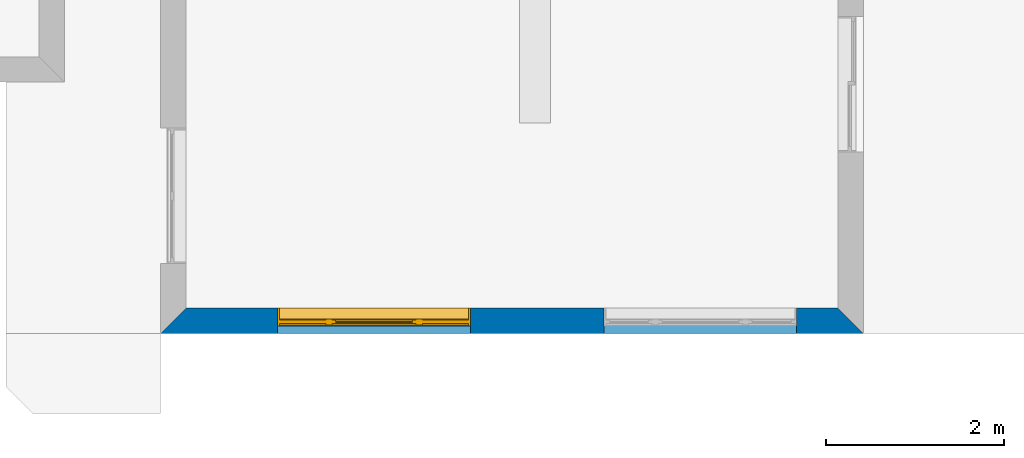
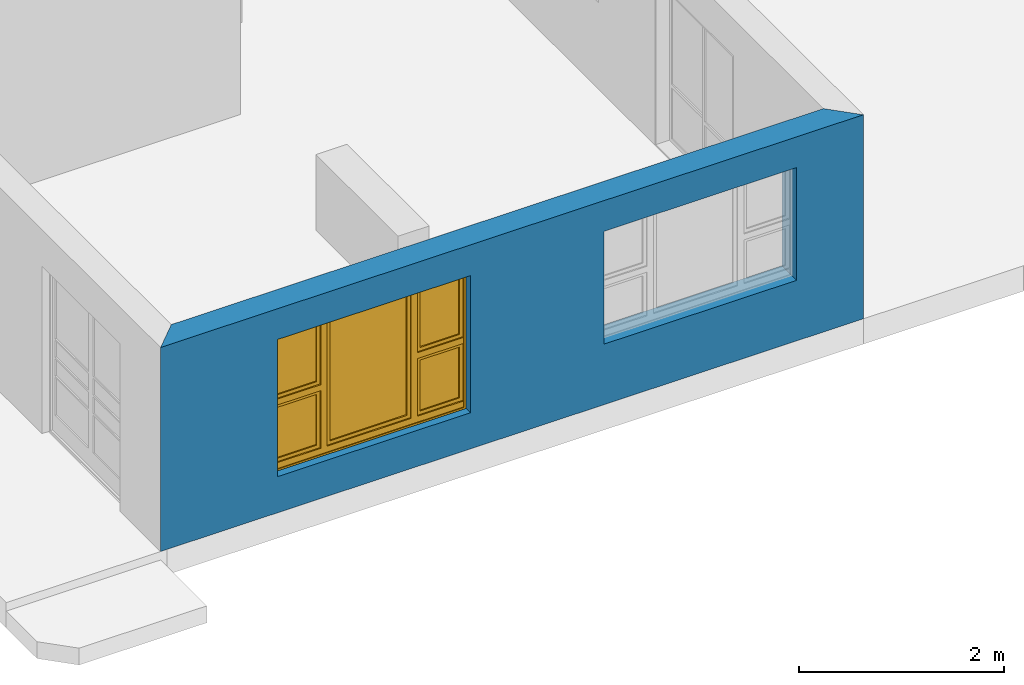
# One storey, part 4 of 15: 1 wall, 1 window, 2 openings.
"""IFC4 building model written with IfcOpenShell, lengths in millimetres."""

from ifc_helpers import new_model, entity, si_unit, converted_unit, frame, origin_with_axes, origin_2d_with_axis, place, context, subcontext, project, spatial, line, indexed_curve, outline, extrude, clip, halfspace, polygons, source, transform, mapped, material, layer, layer_set, layer_usage, type_object, type_shapes, element, fill, save


model = new_model("IFC4")

# Units and contexts
model_context = context("Model", 3, precision=1e-05, world=origin_with_axes())
plan_context = context("Plan", 2, precision=1e-05, world=origin_2d_with_axis())
body_context = subcontext(model_context, "Body", "Model", "MODEL_VIEW")
ifc_project = project(units=[si_unit("VOLUMEUNIT", "CUBIC_METRE"), si_unit("LENGTHUNIT", "METRE", prefix="MILLI"), converted_unit("PLANEANGLEUNIT", "degree", entity("IfcReal", 0.0174532925199433), si_unit("PLANEANGLEUNIT", "RADIAN"), dimensions=[0, 0, 0, 0, 0, 0, 0]), si_unit("AREAUNIT", "SQUARE_METRE")], contexts=[model_context, plan_context])

# Site, building, storey
site_placement = place(None, origin_with_axes())
site = spatial("IfcSite", under=ifc_project, at=site_placement)
building_placement = place(site_placement, origin_with_axes())
building = spatial("IfcBuilding", under=site, at=building_placement, Name="Building")
storey_placement = place(building_placement, origin_with_axes())
storey = spatial("IfcBuildingStorey", under=building, at=storey_placement, Name="EXISTING")

# Wall, openings, window
ifc_material = material()
ifc_layer = layer(ifc_material, 285.0, Name="brick")
ifc_layer_set = layer_set([ifc_layer])
ifc_layer_usage = layer_usage(ifc_layer_set, "AXIS2", "POSITIVE", 0.0)
wall_type = type_object("IfcWallType", Name="285mm Wall", PredefinedType="STANDARD", material=ifc_layer_set)
wall_placement = place(storey_placement, frame((5594.11907196045, -4518.33248138428, 0.0), z_axis=(0.0, 0.0, 1.0), x_axis=(0.999999999999993, 1.19209282445353e-07, 0.0)))
wall = element("IfcWall", 1, at=wall_placement, inside=storey, type_object=wall_type, material=ifc_layer_usage, Name="Wall", context=body_context, shape_type="Clipping", body=[
    clip(clip(extrude(outline(indexed_curve([(0.0, 0.0), (0.0, 285.0), (7900.00095608862, 285.0), (7900.00095608862, 0.0), (0.0, 0.0)], self_intersect=False)), origin_with_axes(), (0.0, 0.0, 1.0), 2425.00019073486), halfspace(frame((7900.00104904175, 0.0, 0.0), z_axis=(0.707107067108154, 0.707106471061707, 0.0), x_axis=(0.707106483163256, -0.707107079209714, 0.0)), False)), halfspace(frame((0.0, 0.0, 0.0), z_axis=(-0.707106471061707, 0.707107067108154, 0.0), x_axis=(0.707107079209714, 0.707106483163256, 0.0)), False)),
])
shared_shape_1 = source(origin_with_axes(), body_context, "Body", "SweptSolid", [
    extrude(outline(indexed_curve([(0.0, 0.0), (2165.00024414062, 0.0), (2165.00024414062, 1629.99987792969), (0.0, 1629.99987792969)], segments=[line(1, 2, 3, 4, 1)])), frame((-1.04308121251506e-07, -600.0, 0.0), z_axis=(0.0, -1.0, 0.0), x_axis=(1.0, 0.0, 0.0)), (0.0, 0.0, -1.0), 1200.0),
])
opening_1_placement = place(wall_placement, frame((3482.00082778931, 136.111021041866, 430.000007152557), z_axis=(0.0, 0.0, 1.0), x_axis=(-0.999999999999989, 1.50995802528085e-07, 0.0)))
opening_1 = element("IfcOpeningElement", 2, at=opening_1_placement, cuts=wall, Name="Opening", PredefinedType="OPENING", context=body_context, shape_type="MappedRepresentation", body=[
    mapped(shared_shape_1, transform((0.0, 0.0, 0.0), x_axis=(1.0, 0.0, 0.0), y_axis=(0.0, 1.0, 0.0), z_axis=(0.0, 0.0, 1.0), scale=1.0)),
])
shared_shape_2 = source(origin_with_axes(), body_context, "Body", "SweptSolid", [
    extrude(outline(indexed_curve([(0.0, 0.0), (2165.00048828125, 0.0), (2165.00048828125, 1340.00048828125), (0.0, 1340.00048828125)], segments=[line(1, 2, 3, 4, 1)])), frame((-5.96046390910487e-07, -600.0, 0.0), z_axis=(0.0, -1.0, 0.0), x_axis=(1.0, 0.0, 0.0)), (0.0, 0.0, -1.0), 1200.0),
])
opening_2_placement = place(wall_placement, frame((7150.00581741333, 136.111021041866, 719.999313354492), z_axis=(0.0, 0.0, 1.0), x_axis=(-0.999999999999989, 1.50995802528085e-07, 0.0)))
element("IfcOpeningElement", 3, at=opening_2_placement, cuts=wall, PredefinedType="OPENING", context=body_context, shape_type="MappedRepresentation", body=[
    mapped(shared_shape_2, transform((0.0, 0.0, 0.0), x_axis=(1.0, 0.0, 0.0), y_axis=(0.0, 1.0, 0.0), z_axis=(0.0, 0.0, 1.0), scale=1.0)),
])
window_type = type_object("IfcWindowType", Name="Ex.2165x1630", PartitioningType="NOTDEFINED", PredefinedType="WINDOW")
shared_shape_3 = source(origin_with_axes(), body_context, "Body", "Tessellation", [
    polygons([(2165.00048828125, -148.88883972168, 0.0), (2165.00048828125, -148.88883972168, 19.9999198913574), (0.000134110436192714, -148.888961791992, 0.0), (0.000134110436192714, -148.888961791992, 19.9999198913574), (2165.00048828125, 51.1111831665039, 0.0), (2165.00048828125, 51.1111831665039, 19.9999198913574), (0.000134110436192714, 51.1110649108887, 0.0), (0.000134110436192714, 51.1110649108887, 19.9999198913574), (2165.00048828125, -148.88883972168, 1609.99975585938), (2165.00048828125, -148.88883972168, 1630.0), (0.000134110436192714, -148.888961791992, 1609.99975585938), (0.000134110436192714, -148.888961791992, 1630.0), (2165.00048828125, 51.1111831665039, 1609.99975585938), (2165.00048828125, 51.1111831665039, 1630.0), (0.000134110436192714, 51.1110649108887, 1609.99975585938), (0.000134110436192714, 51.1110649108887, 1630.0), (0.000134110436192714, -148.88883972168, 19.9999198913574), (20.0003528594971, -148.88883972168, 19.9999198913574), (0.000134110436192714, -148.888961791992, 1609.99975585938), (20.000114440918, -148.888961791992, 1609.99975585938), (0.000134110436192714, 51.1111831665039, 19.9999198913574), (20.000114440918, 51.1111831665039, 19.9999198913574), (-0.000104308121080976, 51.1110649108887, 1609.99975585938), (20.000114440918, 51.1110649108887, 1609.99975585938), (2145.00048828125, -148.88883972168, 19.9999198913574), (2165.00048828125, -148.88883972168, 19.9999198913574), (2145.0, -148.888961791992, 1609.99975585938), (2165.0, -148.888961791992, 1609.99975585938), (2145.00048828125, 51.1111831665039, 19.9999198913574), (2165.00048828125, 51.1111831665039, 19.9999198913574), (2145.0, 51.1110649108887, 1609.99975585938), (2165.0, 51.1110649108887, 1609.99975585938), (1554.99987792969, -28.8888530731201, 19.9999198913574), (1625.0, -28.8888530731201, 19.9999198913574), (1554.99938964844, -28.8888530731201, 1609.99975585938), (1624.99951171875, -28.8888530731201, 1609.99975585938), (1554.99987792969, 41.1110763549805, 19.9999198913574), (1625.0, 41.1110763549805, 19.9999198913574), (1554.99938964844, 41.1110763549805, 1609.99975585938), (1624.99951171875, 41.1110763549805, 1609.99975585938), (540.000061035156, -28.8888530731201, 19.9999198913574), (610.000244140625, -28.8888530731201, 19.9999198913574), (539.999816894531, -28.8888530731201, 1609.99975585938), (610.0, -28.8888530731201, 1609.99975585938), (540.000061035156, 41.1110763549805, 19.9999198913574), (610.000244140625, 41.1110763549805, 19.9999198913574), (539.999816894531, 41.1110763549805, 1609.99975585938), (610.0, 41.1110763549805, 1609.99975585938), (20.000114440918, -28.888973236084, 844.999328613281), (20.000114440918, -28.888973236084, 775.000122070312), (540.000061035156, -28.8888530731201, 845.000061035156), (540.000061035156, -28.8888530731201, 775.000793457031), (20.000114440918, 41.1110763549805, 844.999328613281), (20.000114440918, 41.1110763549805, 775.000122070312), (540.000061035156, 41.1110763549805, 845.000061035156), (540.000061035156, 41.1111946105957, 775.000793457031), (1625.0, -28.888973236084, 844.999328613281), (1625.0, -28.888973236084, 775.000122070312), (2145.0, -28.8888530731201, 845.000061035156), (2145.0, -28.8888530731201, 775.000793457031), (1625.0, 41.1110763549805, 844.999328613281), (1625.0, 41.1110763549805, 775.000122070312), (2145.0, 41.1110763549805, 845.000061035156), (2145.0, 41.1111946105957, 775.000793457031), (1625.0, -13.8889875411987, 1609.99951171875), (1625.0, -13.8889875411987, 1569.99987792969), (2145.0, -13.8888683319092, 1609.99975585938), (2145.0, -13.8888683319092, 1570.00061035156), (1625.0, 26.1110916137695, 1609.99951171875), (1625.0, 26.1110916137695, 1569.99987792969), (2145.0, 26.1110916137695, 1610.00024414062), (2145.0, 26.1110916137695, 1570.00061035156), (1625.0, -13.8889875411987, 884.9990234375), (1625.0, -13.8889875411987, 844.999328613281), (2145.0, -13.8888683319092, 884.99951171875), (2145.0, -13.8888683319092, 844.999938964844), (1625.0, 26.1110916137695, 884.9990234375), (1625.0, 26.1110916137695, 844.999328613281), (2145.0, 26.1110916137695, 884.99951171875), (2145.0, 26.1110916137695, 844.999938964844), (1665.0, -13.8888683319092, 1570.00012207031), (1625.0, -13.8888683319092, 1570.00012207031), (1664.99975585938, -13.8888683319092, 884.9990234375), (1625.0, -13.8888683319092, 884.9990234375), (1665.0, 26.1110916137695, 1570.00012207031), (1625.0, 26.1110916137695, 1570.00012207031), (1664.99975585938, 26.1110916137695, 884.9990234375), (1625.0, 26.1110916137695, 884.9990234375), (2144.99951171875, -13.8888683319092, 1570.00012207031), (2105.00024414062, -13.8888683319092, 1570.00012207031), (2144.99951171875, -13.8888683319092, 884.9990234375), (2104.99975585938, -13.8888683319092, 884.9990234375), (2144.99951171875, 26.1110916137695, 1570.00012207031), (2105.00024414062, 26.1110916137695, 1570.00012207031), (2144.99951171875, 26.1110916137695, 884.9990234375), (2104.99975585938, 26.1110916137695, 884.9990234375), (20.0003528594971, -13.8889875411987, 1609.99951171875), (20.0003528594971, -13.8889875411987, 1569.99987792969), (540.000305175781, -13.8888683319092, 1609.99975585938), (540.000305175781, -13.8888683319092, 1570.00061035156), (20.0003528594971, 26.1110916137695, 1609.99951171875), (20.0003528594971, 26.1110916137695, 1569.99987792969), (540.000305175781, 26.1110916137695, 1610.00024414062), (540.000305175781, 26.1110916137695, 1570.00061035156), (20.0003528594971, -13.8889875411987, 884.9990234375), (20.0003528594971, -13.8889875411987, 844.999328613281), (540.000305175781, -13.8888683319092, 884.99951171875), (540.000305175781, -13.8888683319092, 844.999938964844), (20.0003528594971, 26.1110916137695, 884.9990234375), (20.0003528594971, 26.1110916137695, 844.999328613281), (540.000305175781, 26.1110916137695, 884.99951171875), (540.000305175781, 26.1110916137695, 844.999938964844), (60.0003128051758, -13.8888683319092, 1570.00012207031), (20.0005912780762, -13.8888683319092, 1570.00012207031), (60.000072479248, -13.8888683319092, 884.9990234375), (20.0005912780762, -13.8888683319092, 884.9990234375), (60.0003128051758, 26.1110916137695, 1570.00012207031), (20.0005912780762, 26.1110916137695, 1570.00012207031), (60.000072479248, 26.1110916137695, 884.9990234375), (20.0005912780762, 26.1110916137695, 884.9990234375), (539.999572753906, -13.8888683319092, 1570.00012207031), (499.999847412109, -13.8888683319092, 1570.00012207031), (539.999572753906, -13.8888683319092, 884.9990234375), (499.999603271484, -13.8888683319092, 884.9990234375), (539.999572753906, 26.1110916137695, 1570.00012207031), (499.999847412109, 26.1110916137695, 1570.00012207031), (539.999572753906, 26.1110916137695, 884.9990234375), (499.999603271484, 26.1110916137695, 884.9990234375), (20.000114440918, -28.888973236084, 89.9992523193359), (20.000114440918, -28.888973236084, 19.9997406005859), (540.000061035156, -28.8888530731201, 89.9999694824219), (540.000061035156, -28.8888530731201, 20.0004558563232), (20.000114440918, 41.1110763549805, 89.9992523193359), (20.000114440918, 41.1110763549805, 19.9997406005859), (540.000061035156, 41.1110763549805, 89.9999694824219), (540.000061035156, 41.1111946105957, 20.0004558563232), (1625.0, -28.888973236084, 89.9992523193359), (1625.0, -28.888973236084, 19.9997406005859), (2145.0, -28.8888530731201, 89.9999694824219), (2145.0, -28.8888530731201, 20.0004558563232), (1625.0, 41.1110763549805, 89.9992523193359), (1625.0, 41.1110763549805, 19.9997406005859), (2145.0, 41.1110763549805, 89.9999694824219), (2145.0, 41.1111946105957, 20.0004558563232), (610.000244140625, -28.888973236084, 89.9992523193359), (610.000244140625, -28.888973236084, 19.9997406005859), (1554.99987792969, -28.8888530731201, 89.9999694824219), (1554.99987792969, -28.8888530731201, 20.0004558563232), (610.000244140625, 41.1110763549805, 89.9992523193359), (610.000244140625, 41.1110763549805, 19.9997406005859), (1554.99987792969, 41.1110763549805, 89.9999694824219), (1554.99987792969, 41.1110763549805, 20.0004558563232), (1625.0, -13.8889875411987, 775.000244140625), (1625.0, -13.8889875411987, 735.000366210938), (2145.0, -13.8888683319092, 775.000793457031), (2145.0, -13.8888683319092, 735.001098632812), (1625.0, 26.1110916137695, 775.000244140625), (1625.0, 26.1110916137695, 735.000366210938), (2145.0, 26.1110916137695, 775.000793457031), (2145.0, 26.1110916137695, 735.001098632812), (1625.0, -13.8889875411987, 129.999694824219), (1625.0, -13.8889875411987, 89.9999694824219), (2145.0, -13.8888683319092, 130.00016784668), (2145.0, -13.8888683319092, 90.0005645751953), (1625.0, 26.1110916137695, 129.999694824219), (1625.0, 26.1110916137695, 89.9999694824219), (2145.0, 26.1110916137695, 130.00016784668), (2145.0, 26.1110916137695, 90.0005645751953), (1665.0, -13.8888683319092, 735.000610351562), (1625.0, -13.8888683319092, 735.000610351562), (1664.99975585938, -13.8888683319092, 129.998977661133), (1625.0, -13.8888683319092, 129.999099731445), (1665.0, 26.1110916137695, 735.000610351562), (1625.0, 26.1110916137695, 735.000610351562), (1664.99975585938, 26.1110916137695, 129.998977661133), (1625.0, 26.1110916137695, 129.999099731445), (2144.99951171875, -13.8888683319092, 735.000610351562), (2105.00024414062, -13.8888683319092, 735.000610351562), (2144.99951171875, -13.8888683319092, 129.998977661133), (2104.99975585938, -13.8888683319092, 129.999099731445), (2144.99951171875, 26.1110916137695, 735.000610351562), (2105.00024414062, 26.1110916137695, 735.000610351562), (2144.99951171875, 26.1110916137695, 129.998977661133), (2104.99975585938, 26.1110916137695, 129.999099731445), (20.0003528594971, -13.8889875411987, 775.000244140625), (20.0003528594971, -13.8889875411987, 735.000366210938), (540.000305175781, -13.8888683319092, 775.000793457031), (540.000305175781, -13.8888683319092, 735.001098632812), (20.0003528594971, 26.1110916137695, 775.000244140625), (20.0003528594971, 26.1110916137695, 735.000366210938), (540.000305175781, 26.1110916137695, 775.000793457031), (540.000305175781, 26.1110916137695, 735.001098632812), (20.0003528594971, -13.8889875411987, 129.998611450195), (20.0003528594971, -13.8889875411987, 89.9989547729492), (540.000305175781, -13.8888683319092, 129.999099731445), (540.000305175781, -13.8888683319092, 89.9994354248047), (20.0003528594971, 26.1110916137695, 129.998611450195), (20.0003528594971, 26.1110916137695, 89.9989547729492), (540.000305175781, 26.1110916137695, 129.999206542969), (540.000305175781, 26.1110916137695, 89.9994354248047), (60.0003128051758, -13.8888683319092, 735.000610351562), (20.0005912780762, -13.8888683319092, 735.000610351562), (60.000072479248, -13.8888683319092, 129.998977661133), (20.0005912780762, -13.8888683319092, 129.999099731445), (60.0003128051758, 26.1110916137695, 735.000610351562), (20.0005912780762, 26.1110916137695, 735.000610351562), (60.000072479248, 26.1110916137695, 129.998977661133), (20.0005912780762, 26.1110916137695, 129.999099731445), (539.999572753906, -13.8888683319092, 735.000610351562), (499.999847412109, -13.8888683319092, 735.000610351562), (539.999572753906, -13.8888683319092, 129.998977661133), (499.999603271484, -13.8888683319092, 129.999099731445), (539.999572753906, 26.1110916137695, 735.000610351562), (499.999847412109, 26.1110916137695, 735.000610351562), (539.999572753906, 26.1110916137695, 129.998977661133), (499.999603271484, 26.1110916137695, 129.999099731445), (610.000427246094, -13.8889875411987, 1609.99951171875), (610.000427246094, -13.8889875411987, 1569.99987792969), (1554.99987792969, -13.8888683319092, 1609.99975585938), (1554.99987792969, -13.8888683319092, 1570.00061035156), (610.000427246094, 26.1110916137695, 1609.99951171875), (610.000427246094, 26.1110916137695, 1569.99987792969), (1554.99987792969, 26.1110916137695, 1610.00024414062), (1554.99987792969, 26.1110916137695, 1570.00061035156), (610.000427246094, -13.8889875411987, 129.998916625977), (610.000427246094, -13.8889875411987, 89.9992523193359), (1554.99987792969, -13.8888683319092, 129.999389648438), (1554.99987792969, -13.8888683319092, 89.9997863769531), (610.000427246094, 26.1110916137695, 129.998916625977), (610.000427246094, 26.1110916137695, 89.9992523193359), (1554.99987792969, 26.1110916137695, 129.999389648438), (1554.99987792969, 26.1110916137695, 89.9997863769531), (650.000183105469, -13.8888683319092, 1570.00012207031), (610.000671386719, -13.8888683319092, 1570.00012207031), (650.000183105469, -13.8888683319092, 129.999572753906), (610.000427246094, -13.8888683319092, 129.999572753906), (650.000183105469, 26.1110916137695, 1570.00012207031), (610.000671386719, 26.1110916137695, 1570.00012207031), (650.000183105469, 26.1110916137695, 129.999572753906), (610.000427246094, 26.1110916137695, 129.999572753906), (1554.99987792969, -13.8888683319092, 1570.00012207031), (1515.00012207031, -13.8888683319092, 1570.00012207031), (1554.99987792969, -13.8888683319092, 129.999389648438), (1515.00012207031, -13.8888683319092, 129.999389648438), (1554.99987792969, 26.1110916137695, 1570.00012207031), (1515.00012207031, 26.1110916137695, 1570.00012207031), (1554.99987792969, 26.1110916137695, 129.999389648438), (1515.00012207031, 26.1110916137695, 129.999389648438), (1515.00012207031, 1.11111617088318, 1570.00012207031), (650.001586914062, 1.11111617088318, 1570.00012207031), (1515.00012207031, 1.11111617088318, 129.999450683594), (650.001342773438, 1.11111617088318, 129.999572753906), (1515.00012207031, 11.1111059188843, 1570.00012207031), (650.001586914062, 11.1111059188843, 1570.00012207031), (1515.00012207031, 11.1111059188843, 129.999450683594), (650.001342773438, 11.1111059188843, 129.999572753906), (2104.99877929688, 1.11111617088318, 1570.00012207031), (1665.0, 1.11111617088318, 1570.00012207031), (2104.99877929688, 1.11111617088318, 884.99951171875), (1664.99975585938, 1.11111617088318, 884.99951171875), (2104.99877929688, 11.1111059188843, 1570.00012207031), (1665.0, 11.1111059188843, 1570.00012207031), (2104.99877929688, 11.1111059188843, 884.99951171875), (1664.99975585938, 11.1111059188843, 884.99951171875), (2104.99877929688, 1.11111617088318, 735.000366210938), (1665.0, 1.11111617088318, 735.000610351562), (2104.99877929688, 1.11111617088318, 130.000518798828), (1664.99975585938, 1.11111617088318, 130.000518798828), (2104.99877929688, 11.1111059188843, 735.000366210938), (1665.0, 11.1111059188843, 735.000610351562), (2104.99877929688, 11.1111059188843, 130.000518798828), (1664.99975585938, 11.1111059188843, 130.000518798828), (499.998901367188, 1.11111617088318, 1570.00012207031), (60.0003128051758, 1.11111617088318, 1570.00012207031), (499.998657226562, 1.11111617088318, 884.99951171875), (60.000072479248, 1.11111617088318, 884.99951171875), (499.998901367188, 11.1111059188843, 1570.00012207031), (60.0003128051758, 11.1111059188843, 1570.00012207031), (499.998657226562, 11.1111059188843, 884.99951171875), (60.000072479248, 11.1111059188843, 884.99951171875), (499.998901367188, 1.11111617088318, 735.000366210938), (60.0003128051758, 1.11111617088318, 735.000610351562), (499.998657226562, 1.11111617088318, 130.000518798828), (60.000072479248, 1.11111617088318, 130.000518798828), (499.998901367188, 11.1111059188843, 735.000366210938), (60.0003128051758, 11.1111059188843, 735.000610351562), (499.998657226562, 11.1111059188843, 130.000518798828), (60.000072479248, 11.1111059188843, 130.000518798828)], [[[1, 2, 4, 3]], [[3, 4, 8, 7]], [[7, 8, 6, 5]], [[5, 6, 2, 1]], [[3, 7, 5, 1]], [[8, 4, 2, 6]], [[9, 10, 12, 11]], [[11, 12, 16, 15]], [[15, 16, 14, 13]], [[13, 14, 10, 9]], [[11, 15, 13, 9]], [[16, 12, 10, 14]], [[17, 18, 20, 19]], [[19, 20, 24, 23]], [[23, 24, 22, 21]], [[21, 22, 18, 17]], [[19, 23, 21, 17]], [[24, 20, 18, 22]], [[25, 26, 28, 27]], [[27, 28, 32, 31]], [[31, 32, 30, 29]], [[29, 30, 26, 25]], [[27, 31, 29, 25]], [[32, 28, 26, 30]], [[33, 34, 36, 35]], [[35, 36, 40, 39]], [[39, 40, 38, 37]], [[37, 38, 34, 33]], [[35, 39, 37, 33]], [[40, 36, 34, 38]], [[41, 42, 44, 43]], [[43, 44, 48, 47]], [[47, 48, 46, 45]], [[45, 46, 42, 41]], [[43, 47, 45, 41]], [[48, 44, 42, 46]], [[49, 50, 52, 51]], [[51, 52, 56, 55]], [[55, 56, 54, 53]], [[53, 54, 50, 49]], [[51, 55, 53, 49]], [[56, 52, 50, 54]], [[57, 58, 60, 59]], [[59, 60, 64, 63]], [[63, 64, 62, 61]], [[61, 62, 58, 57]], [[59, 63, 61, 57]], [[64, 60, 58, 62]], [[65, 66, 68, 67]], [[67, 68, 72, 71]], [[71, 72, 70, 69]], [[69, 70, 66, 65]], [[67, 71, 69, 65]], [[72, 68, 66, 70]], [[73, 74, 76, 75]], [[75, 76, 80, 79]], [[79, 80, 78, 77]], [[77, 78, 74, 73]], [[75, 79, 77, 73]], [[80, 76, 74, 78]], [[81, 82, 84, 83]], [[83, 84, 88, 87]], [[87, 88, 86, 85]], [[85, 86, 82, 81]], [[83, 87, 85, 81]], [[88, 84, 82, 86]], [[89, 90, 92, 91]], [[91, 92, 96, 95]], [[95, 96, 94, 93]], [[93, 94, 90, 89]], [[91, 95, 93, 89]], [[96, 92, 90, 94]], [[97, 98, 100, 99]], [[99, 100, 104, 103]], [[103, 104, 102, 101]], [[101, 102, 98, 97]], [[99, 103, 101, 97]], [[104, 100, 98, 102]], [[105, 106, 108, 107]], [[107, 108, 112, 111]], [[111, 112, 110, 109]], [[109, 110, 106, 105]], [[107, 111, 109, 105]], [[112, 108, 106, 110]], [[113, 114, 116, 115]], [[115, 116, 120, 119]], [[119, 120, 118, 117]], [[117, 118, 114, 113]], [[115, 119, 117, 113]], [[120, 116, 114, 118]], [[121, 122, 124, 123]], [[123, 124, 128, 127]], [[127, 128, 126, 125]], [[125, 126, 122, 121]], [[123, 127, 125, 121]], [[128, 124, 122, 126]], [[129, 130, 132, 131]], [[131, 132, 136, 135]], [[135, 136, 134, 133]], [[133, 134, 130, 129]], [[131, 135, 133, 129]], [[136, 132, 130, 134]], [[137, 138, 140, 139]], [[139, 140, 144, 143]], [[143, 144, 142, 141]], [[141, 142, 138, 137]], [[139, 143, 141, 137]], [[144, 140, 138, 142]], [[145, 146, 148, 147]], [[147, 148, 152, 151]], [[151, 152, 150, 149]], [[149, 150, 146, 145]], [[147, 151, 149, 145]], [[152, 148, 146, 150]], [[153, 154, 156, 155]], [[155, 156, 160, 159]], [[159, 160, 158, 157]], [[157, 158, 154, 153]], [[155, 159, 157, 153]], [[160, 156, 154, 158]], [[161, 162, 164, 163]], [[163, 164, 168, 167]], [[167, 168, 166, 165]], [[165, 166, 162, 161]], [[163, 167, 165, 161]], [[168, 164, 162, 166]], [[169, 170, 172, 171]], [[171, 172, 176, 175]], [[175, 176, 174, 173]], [[173, 174, 170, 169]], [[171, 175, 173, 169]], [[176, 172, 170, 174]], [[177, 178, 180, 179]], [[179, 180, 184, 183]], [[183, 184, 182, 181]], [[181, 182, 178, 177]], [[179, 183, 181, 177]], [[184, 180, 178, 182]], [[185, 186, 188, 187]], [[187, 188, 192, 191]], [[191, 192, 190, 189]], [[189, 190, 186, 185]], [[187, 191, 189, 185]], [[192, 188, 186, 190]], [[193, 194, 196, 195]], [[195, 196, 200, 199]], [[199, 200, 198, 197]], [[197, 198, 194, 193]], [[195, 199, 197, 193]], [[200, 196, 194, 198]], [[201, 202, 204, 203]], [[203, 204, 208, 207]], [[207, 208, 206, 205]], [[205, 206, 202, 201]], [[203, 207, 205, 201]], [[208, 204, 202, 206]], [[209, 210, 212, 211]], [[211, 212, 216, 215]], [[215, 216, 214, 213]], [[213, 214, 210, 209]], [[211, 215, 213, 209]], [[216, 212, 210, 214]], [[217, 218, 220, 219]], [[219, 220, 224, 223]], [[223, 224, 222, 221]], [[221, 222, 218, 217]], [[219, 223, 221, 217]], [[224, 220, 218, 222]], [[225, 226, 228, 227]], [[227, 228, 232, 231]], [[231, 232, 230, 229]], [[229, 230, 226, 225]], [[227, 231, 229, 225]], [[232, 228, 226, 230]], [[233, 234, 236, 235]], [[235, 236, 240, 239]], [[239, 240, 238, 237]], [[237, 238, 234, 233]], [[235, 239, 237, 233]], [[240, 236, 234, 238]], [[241, 242, 244, 243]], [[243, 244, 248, 247]], [[247, 248, 246, 245]], [[245, 246, 242, 241]], [[243, 247, 245, 241]], [[248, 244, 242, 246]], [[249, 250, 252, 251]], [[251, 252, 256, 255]], [[255, 256, 254, 253]], [[253, 254, 250, 249]], [[251, 255, 253, 249]], [[256, 252, 250, 254]], [[257, 258, 260, 259]], [[259, 260, 264, 263]], [[263, 264, 262, 261]], [[261, 262, 258, 257]], [[259, 263, 261, 257]], [[264, 260, 258, 262]], [[265, 266, 268, 267]], [[267, 268, 272, 271]], [[271, 272, 270, 269]], [[269, 270, 266, 265]], [[267, 271, 269, 265]], [[272, 268, 266, 270]], [[273, 274, 276, 275]], [[275, 276, 280, 279]], [[279, 280, 278, 277]], [[277, 278, 274, 273]], [[275, 279, 277, 273]], [[280, 276, 274, 278]], [[281, 282, 284, 283]], [[283, 284, 288, 287]], [[287, 288, 286, 285]], [[285, 286, 282, 281]], [[283, 287, 285, 281]], [[288, 284, 282, 286]]], closed=True),
])
type_shapes(window_type, [shared_shape_3])
window_placement = place(opening_1_placement, frame((0.000460611403241273, 0.00113034256798983, 3.88578058618805e-13), z_axis=(0.0, 0.0, 1.0), x_axis=(0.999999999999993, -1.19209282445353e-07, 0.0)))
window = element("IfcWindow", 4, at=window_placement, inside=storey, type_object=window_type, Name="Window", context=body_context, shape_type="MappedRepresentation", body=[
    mapped(shared_shape_3, transform((0.0, 0.0, 0.0), x_axis=(1.0, 0.0, 0.0), y_axis=(0.0, 1.0, 0.0), z_axis=(0.0, 0.0, 1.0), scale=1.0)),
])
fill(opening_1, window)

save(model, "model.ifc")
